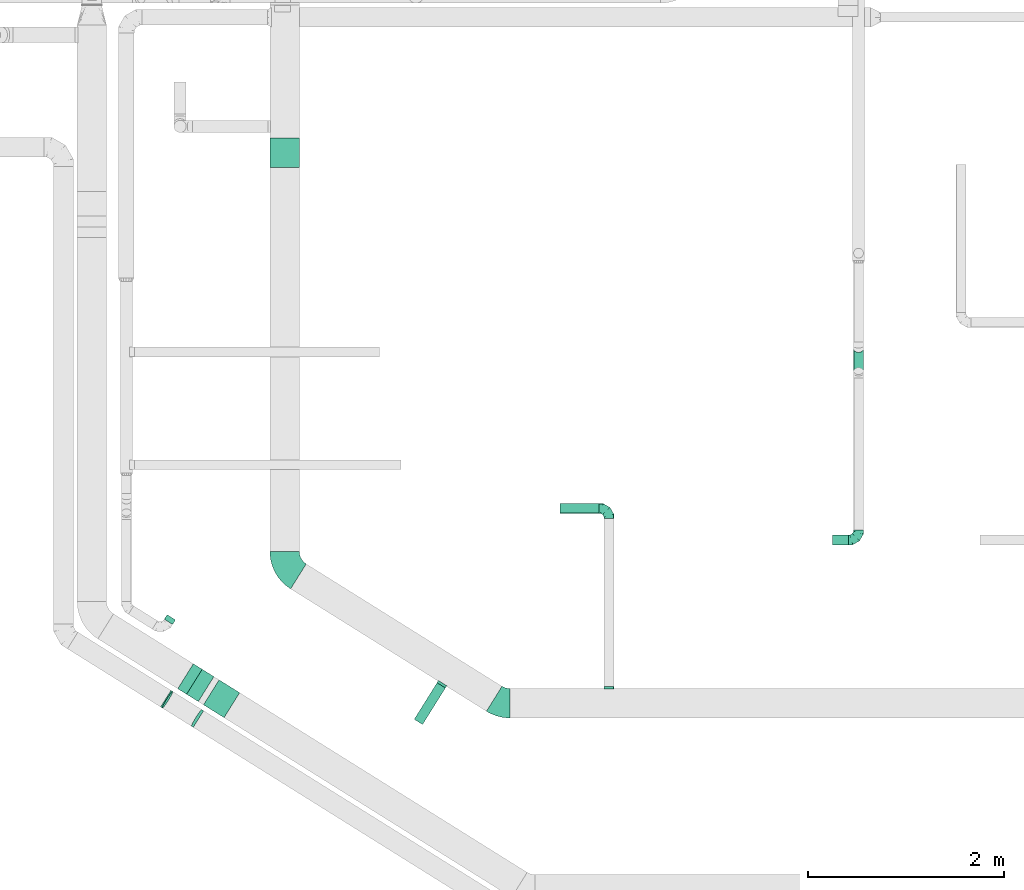
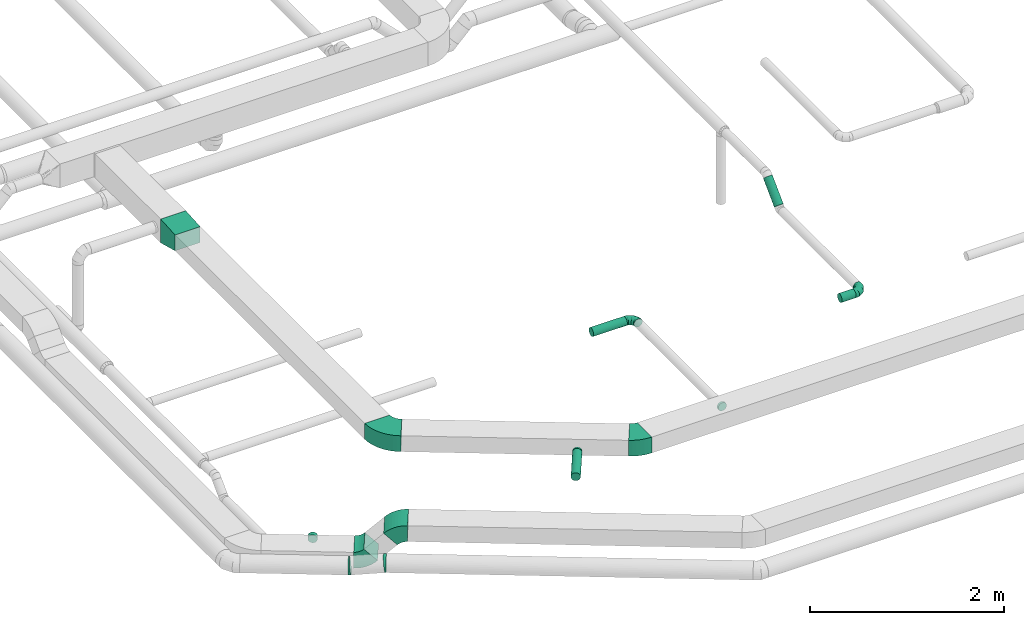
# One storey, part 13 of 60: 11 flow fittings, 5 flow segments.
"""IFC2X3 building model written with IfcOpenShell, lengths in millimetres."""

import ifcopenshell
import ifcopenshell.guid

model = None  # the IFC model being written
_history = None  # IfcOwnerHistory: only IFC2X3 demands one
_inside = {}  # id of a spatial element -> (the spatial element, [elements in it])
_under = {}  # id of a project, library or spatial element -> (it, [spatial elements below it])
_declared = {}  # id of a project -> (the project, [libraries it declares])
_typed = {}  # id of a type object -> (the type object, [elements of that type])
_made_of = {}  # id of a material, layer set ... -> (it, [elements and type objects made of it])


def new_model(schema):
    """Start an empty IFC model of exactly this schema.

    Asked for "IFC4X3", IfcOpenShell would pick the latest addendum, in which some entities
    have other attributes; the version numbers below select the first issue.
    IFC2X3 requires an IfcOwnerHistory on every rooted entity: one is made here for all.
    """
    global model, _history
    if schema == "IFC4X3":
        model = ifcopenshell.file(schema_version=(4, 3, 0, 0))
    else:
        model = ifcopenshell.file(schema=schema)
    _inside.clear()
    _under.clear()
    _declared.clear()
    _typed.clear()
    _made_of.clear()
    _history = None
    if model.schema == "IFC2X3":
        org = make("IfcOrganization", Name="unknown")
        user = make(
            "IfcPersonAndOrganization",
            ThePerson=make("IfcPerson", FamilyName="unknown"),
            TheOrganization=org,
        )
        app = make(
            "IfcApplication",
            ApplicationDeveloper=org,
            Version="unknown",
            ApplicationFullName="unknown",
            ApplicationIdentifier="unknown",
        )
        _history = make(
            "IfcOwnerHistory",
            OwningUser=user,
            OwningApplication=app,
            ChangeAction="ADDED",
            CreationDate=0,
        )
    return model


def make(cls, **values):
    """One entity of the class cls with the attributes given. An attribute that is None is left unset."""
    return model.create_entity(
        cls, **{name: value for name, value in values.items() if value is not None}
    )


def entity(cls, *values):
    """Any entity or typed value of the class cls, its attributes in the order of the schema. None: left unset."""
    e = model.create_entity(cls)
    for i, value in enumerate(values):
        if value is not None:
            e[i] = value
    return e


def rooted(cls, **values):
    """An entity with a GlobalId (a new one), such as an element, a storey or a relation."""
    return make(cls, GlobalId=ifcopenshell.guid.new(), OwnerHistory=_history, **values)


def si_unit(unit_type, name, prefix=None):
    """IfcSIUnit, for example si_unit("LENGTHUNIT", "METRE", prefix="MILLI")."""
    return make("IfcSIUnit", UnitType=unit_type, Prefix=prefix, Name=name)


def converted_unit(unit_type, name, factor, base, dimensions=None, offset=None):
    """IfcConversionBasedUnit, such as the inch: factor (a typed value) times the base unit."""
    return make(
        "IfcConversionBasedUnit"
        if offset is None
        else "IfcConversionBasedUnitWithOffset",
        ConversionOffset=offset,
        Dimensions=None
        if dimensions is None
        else entity("IfcDimensionalExponents", *dimensions),
        UnitType=unit_type,
        Name=name,
        ConversionFactor=make(
            "IfcMeasureWithUnit", ValueComponent=factor, UnitComponent=base
        ),
    )


def derived_unit(unit_type, elements):
    """IfcDerivedUnit: a product of units, each with its exponent."""
    return make(
        "IfcDerivedUnit",
        Elements=[
            make("IfcDerivedUnitElement", Unit=unit, Exponent=power)
            for unit, power in elements
        ],
        UnitType=unit_type,
    )


def assignment(units):
    """IfcUnitAssignment: the units of a project."""
    return None if units is None else make("IfcUnitAssignment", Units=units)


def point(xyz):
    """IfcCartesianPoint."""
    return None if xyz is None else make("IfcCartesianPoint", Coordinates=xyz)


def direction(xyz):
    """IfcDirection."""
    return None if xyz is None else make("IfcDirection", DirectionRatios=xyz)


def frame(location, z_axis=None, x_axis=None):
    """IfcAxis2Placement3D, a coordinate frame: its origin and axes. An axis left out is left unset."""
    return make(
        "IfcAxis2Placement3D",
        Location=point(location),
        Axis=direction(z_axis),
        RefDirection=direction(x_axis),
    )


def frame_2d(location, x_axis=None):
    """IfcAxis2Placement2D, a coordinate frame in the plane: its origin and x axis."""
    return make(
        "IfcAxis2Placement2D", Location=point(location), RefDirection=direction(x_axis)
    )


def origin():
    """The frame at (0, 0, 0) with its axes left unset."""
    return frame((0.0, 0.0, 0.0))


def origin_2d_with_axis():
    """The frame at (0, 0) in the plane with the x axis (1, 0) written out."""
    return frame_2d((0.0, 0.0), x_axis=(1.0, 0.0))


def place(relative_to, where):
    """IfcLocalPlacement: puts the frame where relative to a parent placement (None: the world)."""
    return make(
        "IfcLocalPlacement", PlacementRelTo=relative_to, RelativePlacement=where
    )


def context(
    kind, dimensions, precision=None, world=None, true_north=None, identifier=None
):
    """IfcGeometricRepresentationContext, for example the 3D "Model" context."""
    return make(
        "IfcGeometricRepresentationContext",
        ContextIdentifier=identifier,
        ContextType=kind,
        CoordinateSpaceDimension=dimensions,
        Precision=precision,
        WorldCoordinateSystem=world,
        TrueNorth=true_north,
    )


def subcontext(parent, identifier, kind, view, scale=None):
    """IfcGeometricRepresentationSubContext, for example "Body" below "Model"."""
    return make(
        "IfcGeometricRepresentationSubContext",
        ContextIdentifier=identifier,
        ContextType=kind,
        ParentContext=parent,
        TargetScale=scale,
        TargetView=view,
    )


def project(units=None, contexts=None):
    """IfcProject with its units and contexts."""
    return rooted(
        "IfcProject",
        Name="project",
        RepresentationContexts=contexts,
        UnitsInContext=assignment(units),
    )


def spatial(cls, under=None, at=None, **own):
    """A site, building, storey or space (cls), placed at a placement, below another one or the project."""
    s = rooted(cls, ObjectPlacement=at, **own)
    if under is not None:
        _under.setdefault(under.id(), (under, []))[1].append(s)
    return s


def polyline(points):
    """IfcPolyline through the points."""
    return make("IfcPolyline", Points=[point(p) for p in points])


def circle_curve(where, radius):
    """IfcCircle in the frame where."""
    return make("IfcCircle", Position=where, Radius=radius)


def parameter(value):
    """IfcParameterValue: where a trimmed curve begins or ends, as a parameter of its basis curve."""
    return model.create_entity("IfcParameterValue", value)


def trimmed(basis, trim1, trim2, sense, master):
    """IfcTrimmedCurve: the piece of a basis curve between two trims."""
    return make(
        "IfcTrimmedCurve",
        BasisCurve=basis,
        Trim1=trim1,
        Trim2=trim2,
        SenseAgreement=sense,
        MasterRepresentation=master,
    )


def segment(curve, same_sense, transition):
    """IfcCompositeCurveSegment."""
    return make(
        "IfcCompositeCurveSegment",
        Transition=transition,
        SameSense=same_sense,
        ParentCurve=curve,
    )


def composite_curve(segments, self_intersect=None):
    """IfcCompositeCurve: segments joined end to end."""
    return make("IfcCompositeCurve", Segments=segments, SelfIntersect=self_intersect)


def profile(cls, at=None, kind="AREA", **sizes):
    """A parametric profile (cls). Its sizes go by their IFC names, for example OverallWidth=200.0."""
    return make(cls, ProfileType=kind, Position=at, **sizes)


def circle(**sizes):
    """IfcCircleProfileDef."""
    return profile("IfcCircleProfileDef", **sizes)


def outline(outer, holes=None, kind="AREA"):
    """IfcArbitraryClosedProfileDef: a profile drawn as a closed curve; with holes, ...WithVoids."""
    if holes is None:
        return make("IfcArbitraryClosedProfileDef", ProfileType=kind, OuterCurve=outer)
    return make(
        "IfcArbitraryProfileDefWithVoids",
        ProfileType=kind,
        OuterCurve=outer,
        InnerCurves=holes,
    )


def extrude(swept, where, along, depth):
    """IfcExtrudedAreaSolid: the profile swept, set in the frame where, extruded along a direction by depth."""
    return make(
        "IfcExtrudedAreaSolid",
        SweptArea=swept,
        Position=where,
        ExtrudedDirection=direction(along),
        Depth=depth,
    )


def faces_of(points, faces, orient=None, outer=None):
    """IfcFace entities. A face is a list of loops; a loop is a list of indices into points, from 0.

    orient and outer hold one flag for each loop. By default every Orientation is true, the
    first loop of a face is its IfcFaceOuterBound and the others are IfcFaceBound.
    """
    made = []
    for i, loops in enumerate(faces):
        bounds = []
        for j, loop in enumerate(loops):
            is_outer = j == 0 if outer is None else outer[i][j]
            bounds.append(
                make(
                    "IfcFaceOuterBound" if is_outer else "IfcFaceBound",
                    Bound=make("IfcPolyLoop", Polygon=[points[k] for k in loop]),
                    Orientation=True if orient is None else orient[i][j],
                )
            )
        made.append(make("IfcFace", Bounds=bounds))
    return made


def faceted_brep(points, faces, orient=None, outer=None, voids=None):
    """IfcFacetedBrep: a solid bounded by flat faces; with voids (closed shells), ...WithVoids."""
    shared = [point(p) for p in points]
    hull = make("IfcClosedShell", CfsFaces=faces_of(shared, faces, orient, outer))
    if voids is None:
        return make("IfcFacetedBrep", Outer=hull)
    return make(
        "IfcFacetedBrepWithVoids",
        Outer=hull,
        Voids=[
            make(cls, CfsFaces=faces_of(shared, fs, o, b)) for cls, fs, o, b in voids
        ],
    )


def shape(context_of_items, identifier, shape_type, items):
    """IfcShapeRepresentation: the items that make up one representation, for example the "Body"."""
    return make(
        "IfcShapeRepresentation",
        ContextOfItems=context_of_items,
        RepresentationIdentifier=identifier,
        RepresentationType=shape_type,
        Items=items,
    )


def source(mapping_origin, context_of_items, identifier, shape_type, items):
    """IfcRepresentationMap: a shape defined once, which mapped items show again and again."""
    return make(
        "IfcRepresentationMap",
        MappingOrigin=mapping_origin,
        MappedRepresentation=shape(context_of_items, identifier, shape_type, items),
    )


def transform(
    local_origin,
    x_axis=None,
    y_axis=None,
    z_axis=None,
    scale=None,
    scale2=None,
    scale3=None,
    uniform=True,
):
    """IfcCartesianTransformationOperator3D, or its non-uniform kind. x_axis, y_axis, z_axis: its Axis1, 2, 3."""
    if uniform:
        return make(
            "IfcCartesianTransformationOperator3D",
            Axis1=direction(x_axis),
            Axis2=direction(y_axis),
            LocalOrigin=point(local_origin),
            Scale=scale,
            Axis3=direction(z_axis),
        )
    return make(
        "IfcCartesianTransformationOperator3DnonUniform",
        Axis1=direction(x_axis),
        Axis2=direction(y_axis),
        LocalOrigin=point(local_origin),
        Scale=scale,
        Axis3=direction(z_axis),
        Scale2=scale2,
        Scale3=scale3,
    )


def mapped(mapping_source, mapping_target):
    """IfcMappedItem: shows the shape of a source again, moved by a transform."""
    return make(
        "IfcMappedItem", MappingSource=mapping_source, MappingTarget=mapping_target
    )


def material(Name=None, Category=None):
    """IfcMaterial."""
    return make("IfcMaterial", Name=Name, Category=Category)


def made_of(thing, what):
    """Note that an element or type object is made of a material, layer set ...; save() writes the relation."""
    if what is not None:
        _made_of.setdefault(what.id(), (what, []))[1].append(thing)
    return thing


def type_object(cls, material=None, **own):
    """A type object (cls), such as IfcWallType, which elements share."""
    return made_of(rooted(cls, **own), material)


def type_shapes(of_type, sources):
    """Give a type object the sources (RepresentationMaps) that its elements show as mapped items."""
    of_type.RepresentationMaps = sources


def element(
    cls,
    number,
    at=None,
    inside=None,
    cuts=None,
    type_object=None,
    material=None,
    context=None,
    identifier="Body",
    shape_type=None,
    held_by="IfcProductDefinitionShape",
    body=None,
    shapes=None,
    **own,
):
    """One element of the class cls, such as IfcWall. Its Tag is "e" and its number.

    at: its placement. inside: the storey or other place that contains it. cuts: it is an
    opening in that element (IfcRelVoidsElement). A single representation is given by context,
    identifier, shape_type and body (its items); several are given by shapes. held_by: the class
    of the entity that holds the representations. save() writes the other relations.
    """
    e = rooted(cls, Tag="e%d" % number, ObjectPlacement=at, **own)
    if body is not None:
        shapes = [shape(context, identifier, shape_type, body)]
    if shapes is not None:
        e.Representation = make(held_by, Representations=shapes)
    if inside is not None:
        _inside.setdefault(inside.id(), (inside, []))[1].append(e)
    if cuts is not None:
        rooted(
            "IfcRelVoidsElement", RelatingBuildingElement=cuts, RelatedOpeningElement=e
        )
    if type_object is not None:
        _typed.setdefault(type_object.id(), (type_object, []))[1].append(e)
    return made_of(e, material)


def aggregate(whole, parts):
    """IfcRelAggregates: a whole, such as a stair, and the parts it consists of."""
    return rooted("IfcRelAggregates", RelatingObject=whole, RelatedObjects=parts)


def save(model, path):
    """Write the relations noted so far, then the file.

    IfcRelAggregates (storeys below a building ...), IfcRelContainedInSpatialStructure (elements
    in a storey), IfcRelDefinesByType, IfcRelAssociatesMaterial and IfcRelDeclares: one each for
    every whole, place, type object, material and project.
    """
    for whole, parts in _under.values():
        aggregate(whole, parts)
    for where, things in _inside.values():
        rooted(
            "IfcRelContainedInSpatialStructure",
            RelatedElements=things,
            RelatingStructure=where,
        )
    for kind, things in _typed.values():
        rooted("IfcRelDefinesByType", RelatedObjects=things, RelatingType=kind)
    for what, things in _made_of.values():
        rooted("IfcRelAssociatesMaterial", RelatedObjects=things, RelatingMaterial=what)
    for by, libraries in _declared.values():
        rooted("IfcRelDeclares", RelatingContext=by, RelatedDefinitions=libraries)
    model.write(path)


model = new_model("IFC2X3")

# Units and contexts
model_context = context("Model", 3, precision=0.01, world=origin(), true_north=direction((6.12303176911189e-17, 1.0)))
body_context = subcontext(model_context, "Body", "Model", "MODEL_VIEW")
ifc_project = project(units=[si_unit("LENGTHUNIT", "METRE", prefix="MILLI"), si_unit("AREAUNIT", "SQUARE_METRE"), si_unit("VOLUMEUNIT", "CUBIC_METRE"), converted_unit("PLANEANGLEUNIT", "DEGREE", entity("IfcRatioMeasure", 0.0174532925199433), si_unit("PLANEANGLEUNIT", "RADIAN"), dimensions=[0, 0, 0, 0, 0, 0, 0]), si_unit("MASSUNIT", "GRAM", prefix="KILO"), derived_unit("MASSDENSITYUNIT", [(si_unit("MASSUNIT", "GRAM", prefix="KILO"), 1), (si_unit("LENGTHUNIT", "METRE"), -3)]), derived_unit("MOMENTOFINERTIAUNIT", [(si_unit("LENGTHUNIT", "METRE"), 4)]), si_unit("TIMEUNIT", "SECOND"), si_unit("FREQUENCYUNIT", "HERTZ"), si_unit("THERMODYNAMICTEMPERATUREUNIT", "DEGREE_CELSIUS"), derived_unit("THERMALTRANSMITTANCEUNIT", [(si_unit("MASSUNIT", "GRAM", prefix="KILO"), 1), (si_unit("THERMODYNAMICTEMPERATUREUNIT", "KELVIN"), -1), (si_unit("TIMEUNIT", "SECOND"), -3)]), derived_unit("VOLUMETRICFLOWRATEUNIT", [(si_unit("LENGTHUNIT", "METRE"), 3), (si_unit("TIMEUNIT", "SECOND"), -1)]), derived_unit("MASSFLOWRATEUNIT", [(si_unit("MASSUNIT", "GRAM", prefix="KILO"), 1), (si_unit("TIMEUNIT", "SECOND"), -1)]), derived_unit("ROTATIONALFREQUENCYUNIT", [(si_unit("TIMEUNIT", "SECOND"), -1)]), si_unit("ELECTRICCURRENTUNIT", "AMPERE"), si_unit("ELECTRICVOLTAGEUNIT", "VOLT"), si_unit("POWERUNIT", "WATT"), si_unit("FORCEUNIT", "NEWTON", prefix="KILO"), si_unit("ILLUMINANCEUNIT", "LUX"), si_unit("LUMINOUSFLUXUNIT", "LUMEN"), si_unit("LUMINOUSINTENSITYUNIT", "CANDELA"), derived_unit("USERDEFINED", [(si_unit("MASSUNIT", "GRAM", prefix="KILO"), -1), (si_unit("LENGTHUNIT", "METRE"), -2), (si_unit("TIMEUNIT", "SECOND"), 3), (si_unit("LUMINOUSFLUXUNIT", "LUMEN"), 1)]), derived_unit("LINEARVELOCITYUNIT", [(si_unit("LENGTHUNIT", "METRE"), 1), (si_unit("TIMEUNIT", "SECOND"), -1)]), si_unit("PRESSUREUNIT", "PASCAL"), derived_unit("USERDEFINED", [(si_unit("LENGTHUNIT", "METRE"), -2), (si_unit("MASSUNIT", "GRAM", prefix="KILO"), 1), (si_unit("TIMEUNIT", "SECOND"), -2)]), derived_unit("LINEARFORCEUNIT", [(si_unit("MASSUNIT", "GRAM", prefix="KILO"), 1), (si_unit("LENGTHUNIT", "METRE"), 1), (si_unit("TIMEUNIT", "SECOND"), -2), (si_unit("LENGTHUNIT", "METRE"), -1)]), derived_unit("PLANARFORCEUNIT", [(si_unit("MASSUNIT", "GRAM", prefix="KILO"), 1), (si_unit("LENGTHUNIT", "METRE"), 1), (si_unit("TIMEUNIT", "SECOND"), -2), (si_unit("LENGTHUNIT", "METRE"), -2)])], contexts=[model_context])

# Site, building, storey
site_placement = place(None, origin())
site = spatial("IfcSite", under=ifc_project, at=site_placement, CompositionType="ELEMENT")
building_placement = place(site_placement, origin())
building = spatial("IfcBuilding", under=site, at=building_placement, CompositionType="ELEMENT")
storey_placement = place(building_placement, frame((0.0, 0.0, 19800.0)))
storey = spatial("IfcBuildingStorey", under=building, at=storey_placement, CompositionType="ELEMENT", Elevation=19800.0)

# Flow segments
duct_segment_type = type_object("IfcDuctSegmentType", PredefinedType="NOTDEFINED")
flow_segment_1_placement = place(storey_placement, frame((21423.21, 4438.46, 3498.4)))
element("IfcFlowSegment", 1, at=flow_segment_1_placement, inside=storey, type_object=duct_segment_type, context=body_context, shape_type="SweptSolid", body=[
    extrude(circle(Radius=50.0, at=origin_2d_with_axis()), frame((0.0, 51.6, 51.6), z_axis=(1.0, 0.0, 0.0), x_axis=(0.0, 1.0, 0.0)), (0.0, 0.0, 1.0), 401.874999999967),
])
flow_segment_2_placement = place(storey_placement, frame((19937.04, 2284.95, 3498.4)))
element("IfcFlowSegment", 2, at=flow_segment_2_placement, inside=storey, type_object=duct_segment_type, context=body_context, shape_type="SweptSolid", body=[
    extrude(circle(Radius=50.0, at=origin_2d_with_axis()), frame((44.0, 28.09, 51.6), z_axis=(0.529911826412044, 0.848052743777562, 0.0), x_axis=(-0.848052743777562, 0.529911826412044, 0.0)), (0.0, 0.0, 1.0), 439.999999999993),
])
flow_segment_3_placement = place(storey_placement, frame((17387.11, 3305.72, 2988.4)))
element("IfcFlowSegment", 3, at=flow_segment_3_placement, inside=storey, type_object=duct_segment_type, context=body_context, shape_type="SweptSolid", body=[
    extrude(circle(Radius=50.0, at=origin_2d_with_axis()), frame((44.0, 28.09, 51.6), z_axis=(0.529911826411771, 0.848052743777733, 0.0), x_axis=(0.848052743777733, -0.529911826411771, 0.0)), (0.0, 0.0, 1.0), 54.6426906349968),
])
flow_segment_4_placement = place(storey_placement, frame((24203.34, 4118.35, 3148.4)))
element("IfcFlowSegment", 4, at=flow_segment_4_placement, inside=storey, type_object=duct_segment_type, context=body_context, shape_type="SweptSolid", body=[
    extrude(circle(Radius=50.0, at=origin_2d_with_axis()), frame((0.0, 51.6, 51.6), z_axis=(1.0, 0.0, 0.0), x_axis=(0.0, 1.0, 0.0)), (0.0, 0.0, 1.0), 166.875000000008),
])
flow_segment_5_placement = place(storey_placement, frame((24418.62, 5854.72, 3192.34)))
element("IfcFlowSegment", 5, at=flow_segment_5_placement, inside=storey, type_object=duct_segment_type, context=body_context, shape_type="SweptSolid", body=[
    extrude(circle(Radius=50.0, at=origin_2d_with_axis()), frame((51.6, 36.95, 36.95), z_axis=(0.0, 0.707106781186558, 0.707106781186537), x_axis=(1.0, 0.0, 0.0)), (0.0, 0.0, 1.0), 320.208163660051),
])

# Flow fittings
ifc_material = material()
duct_fitting_type_1 = type_object("IfcDuctFittingType", PredefinedType="NOTDEFINED", material=ifc_material)
shared_shape_1 = source(origin(), body_context, "Body", "SweptSolid", [
    extrude(outline(polyline([(-142.02, -124.72), (158.65, -124.72), (138.69, 174.61), (-155.32, 74.83), (-142.02, -124.72)])), frame((150.0, -150.0, -15.0), z_axis=(0.0, 1.0, 0.0), x_axis=(0.997785157856618, 0.0, 0.0665190105236431)), (0.0, 0.0, 1.0), 300.0),
])
type_shapes(duct_fitting_type_1, [shared_shape_1])
flow_fitting_1_placement = place(storey_placement, frame((18616.2, 7970.16, 3600.0), z_axis=(0.0, 0.0, 1.0), x_axis=(0.0, 1.0, 0.0)))
element("IfcFlowFitting", 6, at=flow_fitting_1_placement, inside=storey, type_object=duct_fitting_type_1, material=ifc_material, context=body_context, shape_type="MappedRepresentation", body=[
    mapped(shared_shape_1, transform((0.0, 0.0, 0.0), scale=1.0)),
])
duct_fitting_type_2 = type_object("IfcDuctFittingType", PredefinedType="NOTDEFINED", material=ifc_material)
shared_shape_2 = source(origin(), body_context, "Body", "Brep", [
    faceted_brep([(-100.0, 0.0, -50.0), (-100.0, -12.94, -48.3), (-100.0, -25.0, -43.3), (-100.0, -35.36, -35.36), (-100.0, -43.3, -25.0), (-100.0, -48.3, -12.94), (-100.0, -50.0, 0.0), (-100.0, -48.3, 12.94), (-100.0, -43.3, 25.0), (-100.0, -35.36, 35.36), (-100.0, -25.0, 43.3), (-100.0, -12.94, 48.3), (-100.0, 0.0, 50.0), (-100.0, 12.94, 48.3), (-100.0, 25.0, 43.3), (-100.0, 35.36, 35.36), (-100.0, 43.3, 25.0), (-100.0, 48.3, 12.94), (-100.0, 50.0, 0.0), (-100.0, 48.3, -12.94), (-100.0, 43.3, -25.0), (-100.0, 35.36, -35.36), (-100.0, 25.0, -43.3), (-100.0, 12.94, -48.3), (-76.67, 12.94, 48.3), (-79.9, 25.0, 43.3), (-73.21, 0.0, 50.0), (-82.68, 35.36, 35.36), (-86.15, 48.3, 12.94), (-86.6, 50.0, 0.0), (-84.81, 43.3, 25.0), (-84.81, 43.3, -25.0), (-82.68, 35.36, -35.36), (-86.15, 48.3, -12.94), (-76.67, 12.94, -48.3), (-73.21, 0.0, -50.0), (-79.9, 25.0, -43.3), (-69.74, -12.94, -48.3), (-66.51, -25.0, -43.3), (-63.73, -35.36, -35.36), (-61.6, -43.3, -25.0), (-60.26, -48.3, -12.94), (-59.81, -50.0, 0.0), (-60.26, -48.3, 12.94), (-61.6, -43.3, 25.0), (-63.73, -35.36, 35.36), (-66.51, -25.0, 43.3), (-69.74, -12.94, 48.3), (-36.27, 36.27, 48.3), (-45.1, 45.1, 43.3), (-26.79, 26.79, 50.0), (-52.68, 52.68, 35.36), (-58.49, 58.49, 25.0), (-62.15, 62.15, 12.94), (-63.4, 63.4, 0.0), (-62.15, 62.15, -12.94), (-58.49, 58.49, -25.0), (-52.68, 52.68, -35.36), (-36.27, 36.27, -48.3), (-26.79, 26.79, -50.0), (-45.1, 45.1, -43.3), (-17.32, 17.32, -48.3), (-8.49, 8.49, -43.3), (-0.91, 0.91, -35.36), (4.9, -4.9, -25.0), (8.56, -8.56, -12.94), (9.81, -9.81, 0.0), (8.56, -8.56, 12.94), (4.9, -4.9, 25.0), (-0.91, 0.91, 35.36), (-8.49, 8.49, 43.3), (-17.32, 17.32, 48.3), (-12.94, 76.67, 48.3), (-25.0, 79.9, 43.3), (0.0, 73.21, 50.0), (-35.36, 82.68, 35.36), (-43.3, 84.81, 25.0), (-48.3, 86.15, 12.94), (-50.0, 86.6, 0.0), (-48.3, 86.15, -12.94), (-43.3, 84.81, -25.0), (-35.36, 82.68, -35.36), (-12.94, 76.67, -48.3), (0.0, 73.21, -50.0), (-25.0, 79.9, -43.3), (12.94, 69.74, -48.3), (25.0, 66.51, -43.3), (35.36, 63.73, -35.36), (43.3, 61.6, -25.0), (48.3, 60.26, -12.94), (50.0, 59.81, 0.0), (48.3, 60.26, 12.94), (43.3, 61.6, 25.0), (35.36, 63.73, 35.36), (25.0, 66.51, 43.3), (12.94, 69.74, 48.3), (-12.94, 100.0, -48.3), (-25.0, 100.0, -43.3), (-35.36, 100.0, -35.36), (-43.3, 100.0, -25.0), (-48.3, 100.0, -12.94), (-50.0, 100.0, 0.0), (-48.3, 100.0, 12.94), (-43.3, 100.0, 25.0), (-35.36, 100.0, 35.36), (-25.0, 100.0, 43.3), (-12.94, 100.0, 48.3), (0.0, 100.0, 50.0), (12.94, 100.0, 48.3), (25.0, 100.0, 43.3), (35.36, 100.0, 35.36), (43.3, 100.0, 25.0), (48.3, 100.0, 12.94), (50.0, 100.0, 0.0), (48.3, 100.0, -12.94), (43.3, 100.0, -25.0), (35.36, 100.0, -35.36), (25.0, 100.0, -43.3), (12.94, 100.0, -48.3), (0.0, 100.0, -50.0)], [[[0, 1, 2, 3, 4, 5, 6, 7, 8, 9, 10, 11, 12, 13, 14, 15, 16, 17, 18, 19, 20, 21, 22, 23]], [[24, 25, 14, 13]], [[26, 24, 13, 12]], [[14, 25, 27, 15]], [[28, 29, 18, 17]], [[30, 28, 17, 16]], [[15, 27, 30, 16]], [[20, 31, 32, 21]], [[33, 31, 20, 19]], [[18, 29, 33, 19]], [[34, 35, 0, 23]], [[36, 34, 23, 22]], [[32, 36, 22, 21]], [[2, 1, 37, 38]], [[3, 2, 38, 39]], [[0, 35, 37, 1]], [[5, 4, 40, 41]], [[6, 5, 41, 42]], [[3, 39, 40, 4]], [[6, 42, 43, 7]], [[7, 43, 44, 8]], [[8, 44, 45, 9]], [[10, 46, 47, 11]], [[11, 47, 26, 12]], [[10, 9, 45, 46]], [[48, 49, 25, 24]], [[50, 48, 24, 26]], [[27, 25, 49, 51]], [[52, 53, 28, 30]], [[51, 52, 30, 27]], [[29, 28, 53, 54]], [[55, 56, 31, 33]], [[54, 55, 33, 29]], [[57, 32, 31, 56]], [[58, 59, 35, 34]], [[60, 58, 34, 36]], [[57, 60, 36, 32]], [[37, 35, 59, 61]], [[38, 37, 61, 62]], [[39, 38, 62, 63]], [[41, 40, 64, 65]], [[42, 41, 65, 66]], [[63, 64, 40, 39]], [[43, 42, 66, 67]], [[44, 43, 67, 68]], [[68, 69, 45, 44]], [[46, 45, 69, 70]], [[47, 46, 70, 71]], [[26, 47, 71, 50]], [[72, 73, 49, 48]], [[74, 72, 48, 50]], [[51, 49, 73, 75]], [[76, 77, 53, 52]], [[75, 76, 52, 51]], [[54, 53, 77, 78]], [[79, 80, 56, 55]], [[78, 79, 55, 54]], [[81, 57, 56, 80]], [[82, 83, 59, 58]], [[84, 82, 58, 60]], [[81, 84, 60, 57]], [[61, 59, 83, 85]], [[62, 61, 85, 86]], [[63, 62, 86, 87]], [[65, 64, 88, 89]], [[66, 65, 89, 90]], [[87, 88, 64, 63]], [[67, 66, 90, 91]], [[68, 67, 91, 92]], [[92, 93, 69, 68]], [[70, 69, 93, 94]], [[71, 70, 94, 95]], [[50, 71, 95, 74]], [[96, 97, 98, 99, 100, 101, 102, 103, 104, 105, 106, 107, 108, 109, 110, 111, 112, 113, 114, 115, 116, 117, 118, 119]], [[72, 74, 107, 106]], [[73, 72, 106, 105]], [[75, 73, 105, 104]], [[77, 76, 103, 102]], [[78, 77, 102, 101]], [[75, 104, 103, 76]], [[78, 101, 100, 79]], [[79, 100, 99, 80]], [[80, 99, 98, 81]], [[96, 119, 83, 82]], [[97, 96, 82, 84]], [[84, 81, 98, 97]], [[83, 119, 118, 85]], [[85, 118, 117, 86]], [[86, 117, 116, 87]], [[88, 115, 114, 89]], [[89, 114, 113, 90]], [[87, 116, 115, 88]], [[91, 90, 113, 112]], [[92, 91, 112, 111]], [[93, 92, 111, 110]], [[95, 94, 109, 108]], [[74, 95, 108, 107]], [[110, 109, 94, 93]]]),
])
type_shapes(duct_fitting_type_2, [shared_shape_2])
flow_fitting_2_placement = place(storey_placement, frame((21925.08, 4490.05, 3550.0), z_axis=(0.0, 0.0, 1.0), x_axis=(0.0, 1.0, 0.0)))
element("IfcFlowFitting", 7, at=flow_fitting_2_placement, inside=storey, type_object=duct_fitting_type_2, material=ifc_material, context=body_context, shape_type="MappedRepresentation", body=[
    mapped(shared_shape_2, transform((0.0, 0.0, 0.0), scale=1.0)),
])
flow_fitting_3_placement = place(storey_placement, frame((24470.22, 4169.95, 3200.0)))
element("IfcFlowFitting", 8, at=flow_fitting_3_placement, inside=storey, type_object=duct_fitting_type_2, material=ifc_material, context=body_context, shape_type="MappedRepresentation", body=[
    mapped(shared_shape_2, transform((0.0, 0.0, 0.0), scale=1.0)),
])
duct_fitting_type_3 = type_object("IfcDuctFittingType", PredefinedType="NOTDEFINED", material=ifc_material)
shared_shape_3 = source(origin(), body_context, "Body", "Brep", [
    faceted_brep([(20.0, 0.0, -50.0), (20.0, 12.94, -48.3), (20.0, 25.0, -43.3), (20.0, 35.36, -35.36), (20.0, 43.3, -25.0), (20.0, 48.3, -12.94), (20.0, 50.0, 0.0), (20.0, 48.3, 12.94), (20.0, 43.3, 25.0), (20.0, 35.36, 35.36), (20.0, 25.0, 43.3), (20.0, 12.94, 48.3), (20.0, 0.0, 50.0), (20.0, -12.94, 48.3), (20.0, -25.0, 43.3), (20.0, -35.36, 35.36), (20.0, -43.3, 25.0), (20.0, -48.3, 12.94), (20.0, -50.0, 0.0), (20.0, -48.3, -12.94), (20.0, -43.3, -25.0), (20.0, -35.36, -35.36), (20.0, -25.0, -43.3), (20.0, -12.94, -48.3), (0.0, 0.0, 50.0), (-6.1, 0.0, 50.0), (-6.1, -12.94, 48.3), (0.0, -12.94, 48.3), (-6.1, -25.0, 43.3), (0.0, -25.0, 43.3), (0.0, -35.36, 35.36), (-6.1, -35.36, 35.36), (0.0, -43.3, 25.0), (-6.1, -43.3, 25.0), (-6.1, -48.3, 12.94), (0.0, -48.3, 12.94), (-6.1, -50.0, 0.0), (0.0, -50.0, 0.0), (-6.1, -48.3, -12.94), (0.0, -48.3, -12.94), (-6.1, -43.3, -25.0), (0.0, -43.3, -25.0), (0.0, -35.36, -35.36), (-6.1, -35.36, -35.36), (0.0, -25.0, -43.3), (-6.1, -25.0, -43.3), (-6.1, -12.94, -48.3), (0.0, -12.94, -48.3), (-6.1, 0.0, -50.0), (0.0, 0.0, -50.0), (-6.1, 12.94, -48.3), (0.0, 12.94, -48.3), (-6.1, 25.0, -43.3), (0.0, 25.0, -43.3), (0.0, 35.36, -35.36), (-6.1, 35.36, -35.36), (0.0, 43.3, -25.0), (-6.1, 43.3, -25.0), (-6.1, 48.3, -12.94), (0.0, 48.3, -12.94), (-6.1, 50.0, 0.0), (0.0, 50.0, 0.0), (-6.1, 48.3, 12.94), (0.0, 48.3, 12.94), (-6.1, 43.3, 25.0), (0.0, 43.3, 25.0), (0.0, 35.36, 35.36), (-6.1, 35.36, 35.36), (0.0, 25.0, 43.3), (-6.1, 25.0, 43.3), (-6.1, 12.94, 48.3), (0.0, 12.94, 48.3)], [[[0, 1, 2, 3, 4, 5, 6, 7, 8, 9, 10, 11, 12, 13, 14, 15, 16, 17, 18, 19, 20, 21, 22, 23]], [[13, 12, 24, 25, 26, 27]], [[14, 13, 27, 26, 28, 29]], [[30, 15, 14, 29, 28, 31]], [[17, 16, 32, 33, 34, 35]], [[18, 17, 35, 34, 36, 37]], [[32, 16, 15, 30, 31, 33]], [[19, 18, 37, 36, 38, 39]], [[20, 19, 39, 38, 40, 41]], [[42, 21, 20, 41, 40, 43]], [[23, 22, 44, 45, 46, 47]], [[0, 23, 47, 46, 48, 49]], [[44, 22, 21, 42, 43, 45]], [[1, 0, 49, 48, 50, 51]], [[2, 1, 51, 50, 52, 53]], [[54, 3, 2, 53, 52, 55]], [[5, 4, 56, 57, 58, 59]], [[6, 5, 59, 58, 60, 61]], [[56, 4, 3, 54, 55, 57]], [[7, 6, 61, 60, 62, 63]], [[8, 7, 63, 62, 64, 65]], [[66, 9, 8, 65, 64, 67]], [[11, 10, 68, 69, 70, 71]], [[12, 11, 71, 70, 25, 24]], [[68, 10, 9, 66, 67, 69]], [[46, 45, 43, 40, 38, 36, 34, 33, 31, 28, 26, 25, 70, 69, 67, 64, 62, 60, 58, 57, 55, 52, 50, 48]]]),
])
type_shapes(duct_fitting_type_3, [shared_shape_3])
flow_fitting_4_placement = place(storey_placement, frame((21925.08, 2653.8, 3550.0), z_axis=(0.0, 0.0, -1.0), x_axis=(0.0, 1.0, 0.0)))
element("IfcFlowFitting", 9, at=flow_fitting_4_placement, inside=storey, type_object=duct_fitting_type_3, material=ifc_material, context=body_context, shape_type="MappedRepresentation", body=[
    mapped(shared_shape_3, transform((0.0, 0.0, 0.0), scale=1.0)),
])
duct_fitting_type_4 = type_object("IfcDuctFittingType", PredefinedType="NOTDEFINED", material=ifc_material)
shared_shape_4 = source(origin(), body_context, "Body", "Brep", [
    faceted_brep([(20.0, 12.94, -48.3), (20.0, 25.0, -43.3), (20.0, 35.36, -35.36), (20.0, 43.3, -25.0), (20.0, 48.3, -12.94), (20.0, 50.0, 0.0), (20.0, 48.3, 12.94), (20.0, 43.3, 25.0), (20.0, 35.36, 35.36), (20.0, 25.0, 43.3), (20.0, 12.94, 48.3), (20.0, 0.0, 50.0), (20.0, -12.94, 48.3), (20.0, -25.0, 43.3), (20.0, -35.36, 35.36), (20.0, -43.3, 25.0), (20.0, -48.3, 12.94), (20.0, -50.0, 0.0), (20.0, -48.3, -12.94), (20.0, -43.3, -25.0), (20.0, -35.36, -35.36), (20.0, -25.0, -43.3), (20.0, -12.94, -48.3), (20.0, 0.0, -50.0), (0.0, 0.0, 50.0), (0.0, 12.94, 48.3), (-6.1, 12.94, 48.3), (-6.1, 0.0, 50.0), (0.0, 25.0, 43.3), (-6.1, 25.0, 43.3), (0.0, 35.36, 35.36), (-6.1, 35.36, 35.36), (0.0, 43.3, 25.0), (0.0, 48.3, 12.94), (-6.1, 48.3, 12.94), (-6.1, 43.3, 25.0), (0.0, 50.0, 0.0), (-6.1, 50.0, 0.0), (0.0, 48.3, -12.94), (-6.1, 48.3, -12.94), (0.0, 43.3, -25.0), (-6.1, 43.3, -25.0), (0.0, 35.36, -35.36), (-6.1, 35.36, -35.36), (0.0, 25.0, -43.3), (0.0, 12.94, -48.3), (-6.1, 12.94, -48.3), (-6.1, 25.0, -43.3), (0.0, 0.0, -50.0), (-6.1, 0.0, -50.0), (0.0, -12.94, -48.3), (-6.1, -12.94, -48.3), (0.0, -25.0, -43.3), (-6.1, -25.0, -43.3), (0.0, -35.36, -35.36), (-6.1, -35.36, -35.36), (0.0, -43.3, -25.0), (0.0, -48.3, -12.94), (-6.1, -48.3, -12.94), (-6.1, -43.3, -25.0), (0.0, -50.0, 0.0), (-6.1, -50.0, 0.0), (0.0, -48.3, 12.94), (-6.1, -48.3, 12.94), (0.0, -43.3, 25.0), (-6.1, -43.3, 25.0), (0.0, -35.36, 35.36), (-6.1, -35.36, 35.36), (0.0, -25.0, 43.3), (0.0, -12.94, 48.3), (-6.1, -12.94, 48.3), (-6.1, -25.0, 43.3)], [[[0, 1, 2, 3, 4, 5, 6, 7, 8, 9, 10, 11, 12, 13, 14, 15, 16, 17, 18, 19, 20, 21, 22, 23]], [[24, 11, 10, 25, 26, 27]], [[25, 10, 9, 28, 29, 26]], [[28, 9, 8, 30, 31, 29]], [[32, 7, 6, 33, 34, 35]], [[33, 6, 5, 36, 37, 34]], [[30, 8, 7, 32, 35, 31]], [[36, 5, 4, 38, 39, 37]], [[38, 4, 3, 40, 41, 39]], [[40, 3, 2, 42, 43, 41]], [[44, 1, 0, 45, 46, 47]], [[45, 0, 23, 48, 49, 46]], [[42, 2, 1, 44, 47, 43]], [[48, 23, 22, 50, 51, 49]], [[50, 22, 21, 52, 53, 51]], [[52, 21, 20, 54, 55, 53]], [[56, 19, 18, 57, 58, 59]], [[57, 18, 17, 60, 61, 58]], [[54, 20, 19, 56, 59, 55]], [[60, 17, 16, 62, 63, 61]], [[62, 16, 15, 64, 65, 63]], [[64, 15, 14, 66, 67, 65]], [[68, 13, 12, 69, 70, 71]], [[69, 12, 11, 24, 27, 70]], [[66, 14, 13, 68, 71, 67]], [[49, 51, 53, 55, 59, 58, 61, 63, 65, 67, 71, 70, 27, 26, 29, 31, 35, 34, 37, 39, 41, 43, 47, 46]]]),
])
type_shapes(duct_fitting_type_4, [shared_shape_4])
flow_fitting_5_placement = place(storey_placement, frame((20224.79, 2703.14, 3550.0), z_axis=(0.0, 0.0, -1.0), x_axis=(-0.529911826412027, -0.848052743777573, 0.0)))
element("IfcFlowFitting", 10, at=flow_fitting_5_placement, inside=storey, type_object=duct_fitting_type_4, material=ifc_material, context=body_context, shape_type="MappedRepresentation", body=[
    mapped(shared_shape_4, transform((0.0, 0.0, 0.0), scale=1.0)),
])
duct_fitting_type_5 = type_object("IfcDuctFittingType", PredefinedType="NOTDEFINED", material=ifc_material)
shared_shape_5 = source(origin(), body_context, "Body", "Brep", [
    faceted_brep([(-10.7, 0.0, -100.0), (-10.7, -25.88, -96.59), (-10.7, -50.0, -86.6), (-10.7, -70.71, -70.71), (-10.7, -86.6, -50.0), (-10.7, -96.59, -25.88), (-10.7, -100.0, 0.0), (-10.7, -96.59, 25.88), (-10.7, -86.6, 50.0), (-10.7, -70.71, 70.71), (-10.7, -50.0, 86.6), (-10.7, -25.88, 96.59), (-10.7, 0.0, 100.0), (-10.7, 25.88, 96.59), (-10.7, 50.0, 86.6), (-10.7, 70.71, 70.71), (-10.7, 86.6, 50.0), (-10.7, 96.59, 25.88), (-10.7, 100.0, 0.0), (-10.7, 96.59, -25.88), (-10.7, 86.6, -50.0), (-10.7, 70.71, -70.71), (-10.7, 50.0, -86.6), (-10.7, 25.88, -96.59), (-1.38, 25.88, 96.59), (-2.67, 50.0, 86.6), (0.0, 0.0, 100.0), (-3.78, 70.71, 70.71), (-5.17, 96.59, 25.88), (-5.35, 100.0, 0.0), (-4.63, 86.6, 50.0), (-4.63, 86.6, -50.0), (-3.78, 70.71, -70.71), (-5.17, 96.59, -25.88), (-1.38, 25.88, -96.59), (0.0, 0.0, -100.0), (-2.67, 50.0, -86.6), (1.38, -25.88, -96.59), (2.67, -50.0, -86.6), (3.78, -70.71, -70.71), (4.63, -86.6, -50.0), (5.17, -96.59, -25.88), (5.35, -100.0, 0.0), (5.17, -96.59, 25.88), (4.63, -86.6, 50.0), (3.78, -70.71, 70.71), (2.67, -50.0, 86.6), (1.38, -25.88, 96.59), (10.64, 1.14, 100.0), (7.87, 26.88, 96.59), (5.3, 50.86, 86.6), (3.09, 71.45, 70.71), (1.4, 87.25, 50.0), (0.33, 97.18, 25.88), (-0.03, 100.57, 0.0), (0.33, 97.18, -25.88), (1.4, 87.25, -50.0), (3.09, 71.45, -70.71), (5.3, 50.86, -86.6), (7.87, 26.88, -96.59), (10.64, 1.14, -100.0), (13.4, -24.59, -96.59), (15.97, -48.57, -86.6), (18.18, -69.17, -70.71), (19.87, -84.97, -50.0), (20.94, -94.9, -25.88), (21.3, -98.29, 0.0), (20.94, -94.9, 25.88), (19.87, -84.97, 50.0), (18.18, -69.17, 70.71), (15.97, -48.57, 86.6), (13.4, -24.59, 96.59)], [[[0, 1, 2, 3, 4, 5, 6, 7, 8, 9, 10, 11, 12, 13, 14, 15, 16, 17, 18, 19, 20, 21, 22, 23]], [[24, 25, 14, 13]], [[26, 24, 13, 12]], [[14, 25, 27, 15]], [[28, 29, 18, 17]], [[30, 28, 17, 16]], [[15, 27, 30, 16]], [[20, 31, 32, 21]], [[33, 31, 20, 19]], [[18, 29, 33, 19]], [[34, 35, 0, 23]], [[36, 34, 23, 22]], [[32, 36, 22, 21]], [[2, 1, 37, 38]], [[3, 2, 38, 39]], [[0, 35, 37, 1]], [[5, 4, 40, 41]], [[6, 5, 41, 42]], [[39, 40, 4, 3]], [[6, 42, 43, 7]], [[7, 43, 44, 8]], [[8, 44, 45, 9]], [[10, 46, 47, 11]], [[11, 47, 26, 12]], [[9, 45, 46, 10]], [[24, 26, 48, 49]], [[25, 24, 49, 50]], [[27, 25, 50, 51]], [[28, 30, 52, 53]], [[29, 28, 53, 54]], [[27, 51, 52, 30]], [[29, 54, 55, 33]], [[33, 55, 56, 31]], [[31, 56, 57, 32]], [[36, 58, 59, 34]], [[34, 59, 60, 35]], [[36, 32, 57, 58]], [[35, 60, 61, 37]], [[37, 61, 62, 38]], [[38, 62, 63, 39]], [[40, 64, 65, 41]], [[41, 65, 66, 42]], [[39, 63, 64, 40]], [[43, 42, 66, 67]], [[44, 43, 67, 68]], [[45, 44, 68, 69]], [[47, 46, 70, 71]], [[26, 47, 71, 48]], [[69, 70, 46, 45]], [[59, 58, 57, 56, 55, 54, 53, 52, 51, 50, 49, 48, 71, 70, 69, 68, 67, 66, 65, 64, 63, 62, 61, 60]]]),
])
type_shapes(duct_fitting_type_5, [shared_shape_5])
for number, where, z_axis, x_axis in (
    (11, (17728.38, 2347.8, 3229.89), (-0.529911826412036, -0.848052743777567, 0.0), (-0.848052743777567, 0.529911826412036, 0.0)),
    (12, (17413.03, 2544.85, 3190.0), (-0.529911826412035, -0.848052743777568, 0.0), (0.848052743777568, -0.529911826412035, 0.0)),
):
    element("IfcFlowFitting", number, at=place(storey_placement, frame(where, z_axis=z_axis, x_axis=x_axis)), inside=storey, type_object=duct_fitting_type_5, material=ifc_material, context=body_context, shape_type="MappedRepresentation", body=[
        mapped(shared_shape_5, transform((0.0, 0.0, 0.0), scale=1.0)),
    ])
duct_fitting_type_6 = type_object("IfcDuctFittingType", PredefinedType="NOTDEFINED", material=ifc_material)
shared_shape_6 = source(origin(), body_context, "Body", "SweptSolid", [
    extrude(outline(composite_curve([segment(polyline([(-136.61, -88.39), (63.39, -88.39)]), True, "CONTINUOUS"), segment(trimmed(circle_curve(frame_2d((213.39, -88.39), x_axis=(-0.707106781186546, 0.707106781186546)), 150.0), [parameter(0.0)], [parameter(45.0)], True, "PARAMETER"), False, "CONTINUOUS"), segment(polyline([(107.32, 17.68), (-34.1, 159.1)]), True, "CONTINUOUS"), segment(trimmed(circle_curve(frame_2d((213.39, -88.39), x_axis=(-0.707106781186546, 0.707106781186546)), 350.0), [parameter(0.0)], [parameter(45.0)], True, "PARAMETER"), True, "CONTINUOUS")], self_intersect=False)), frame((-15.17, 36.61, -150.0), z_axis=(0.0, 0.0, 1.0), x_axis=(-0.707106781186547, 0.707106781186548, 0.0)), (0.0, 0.0, 1.0), 300.0),
])
type_shapes(duct_fitting_type_6, [shared_shape_6])
for number, where, z_axis, x_axis in (
    (13, (17693.58, 2723.85, 3150.0), (-0.529911826412029, -0.848052743777572, 0.0), (0.848052743777572, -0.529911826412029, 0.0)),
    (14, (17990.39, 2538.39, 3500.0), (0.529911826412029, 0.848052743777572, 0.0), (0.599663845928928, -0.374704245886874, 0.707106781186601)),
):
    element("IfcFlowFitting", number, at=place(storey_placement, frame(where, z_axis=z_axis, x_axis=x_axis)), inside=storey, type_object=duct_fitting_type_6, material=ifc_material, context=body_context, shape_type="MappedRepresentation", body=[
        mapped(shared_shape_6, transform((0.0, 0.0, 0.0), scale=1.0)),
    ])
duct_fitting_type_7 = type_object("IfcDuctFittingType", PredefinedType="NOTDEFINED", material=ifc_material)
shared_shape_7 = source(origin(), body_context, "Body", "SweptSolid", [
    extrude(outline(composite_curve([segment(polyline([(-220.51, -127.21), (79.49, -127.21)]), True, "CONTINUOUS"), segment(trimmed(circle_curve(frame_2d((229.49, -127.21), x_axis=(-0.529911826412032, 0.848052743777572)), 150.0), [parameter(0.0)], [parameter(58.0005025122943)], True, "PARAMETER"), False, "CONTINUOUS"), segment(polyline([(150.0, 0.0), (-8.97, 254.42)]), True, "CONTINUOUS"), segment(trimmed(circle_curve(frame_2d((229.49, -127.21), x_axis=(-0.529911826412032, 0.848052743777572)), 450.0), [parameter(0.0)], [parameter(58.0005025122943)], True, "PARAMETER"), True, "CONTINUOUS")], self_intersect=False)), frame((-39.09, 70.51, -100.0), z_axis=(0.0, 0.0, 1.0), x_axis=(-0.848052743777572, 0.529911826412028, 0.0)), (0.0, 0.0, 1.0), 200.0),
])
type_shapes(duct_fitting_type_7, [shared_shape_7])
flow_fitting_6_placement = place(storey_placement, frame((18616.2, 3885.16, 3600.0), z_axis=(0.0, 0.0, 1.0), x_axis=(0.0, -1.0, 0.0)))
element("IfcFlowFitting", 15, at=flow_fitting_6_placement, inside=storey, type_object=duct_fitting_type_7, material=ifc_material, context=body_context, shape_type="MappedRepresentation", body=[
    mapped(shared_shape_7, transform((0.0, 0.0, 0.0), scale=1.0)),
])
duct_fitting_type_8 = type_object("IfcDuctFittingType", PredefinedType="NOTDEFINED", material=ifc_material)
shared_shape_8 = source(origin(), body_context, "Body", "SweptSolid", [
    extrude(outline(composite_curve([segment(polyline([(-172.79, -79.49), (127.21, -79.49)]), True, "CONTINUOUS"), segment(trimmed(circle_curve(frame_2d((277.21, -79.49), x_axis=(-0.848052743777572, 0.529911826412029)), 150.0), [parameter(0.0)], [parameter(31.9994974877059)], True, "PARAMETER"), False, "CONTINUOUS"), segment(polyline([(150.0, 0.0), (-104.42, 158.97)]), True, "CONTINUOUS"), segment(trimmed(circle_curve(frame_2d((277.21, -79.49), x_axis=(-0.848052743777572, 0.529911826412029)), 450.0), [parameter(0.0)], [parameter(31.9994974877059)], True, "PARAMETER"), True, "CONTINUOUS")], self_intersect=False)), frame((-6.54, 22.79, -100.0), z_axis=(0.0, 0.0, 1.0), x_axis=(-0.52991182641203, 0.848052743777571, 0.0)), (0.0, 0.0, 1.0), 200.0),
])
type_shapes(duct_fitting_type_8, [shared_shape_8])
flow_fitting_7_placement = place(storey_placement, frame((20826.88, 2503.8, 3600.0), z_axis=(0.0, 0.0, 1.0), x_axis=(0.848052743777575, -0.529911826412024, 0.0)))
element("IfcFlowFitting", 16, at=flow_fitting_7_placement, inside=storey, type_object=duct_fitting_type_8, material=ifc_material, context=body_context, shape_type="MappedRepresentation", body=[
    mapped(shared_shape_8, transform((0.0, 0.0, 0.0), scale=1.0)),
])

save(model, "model.ifc")
